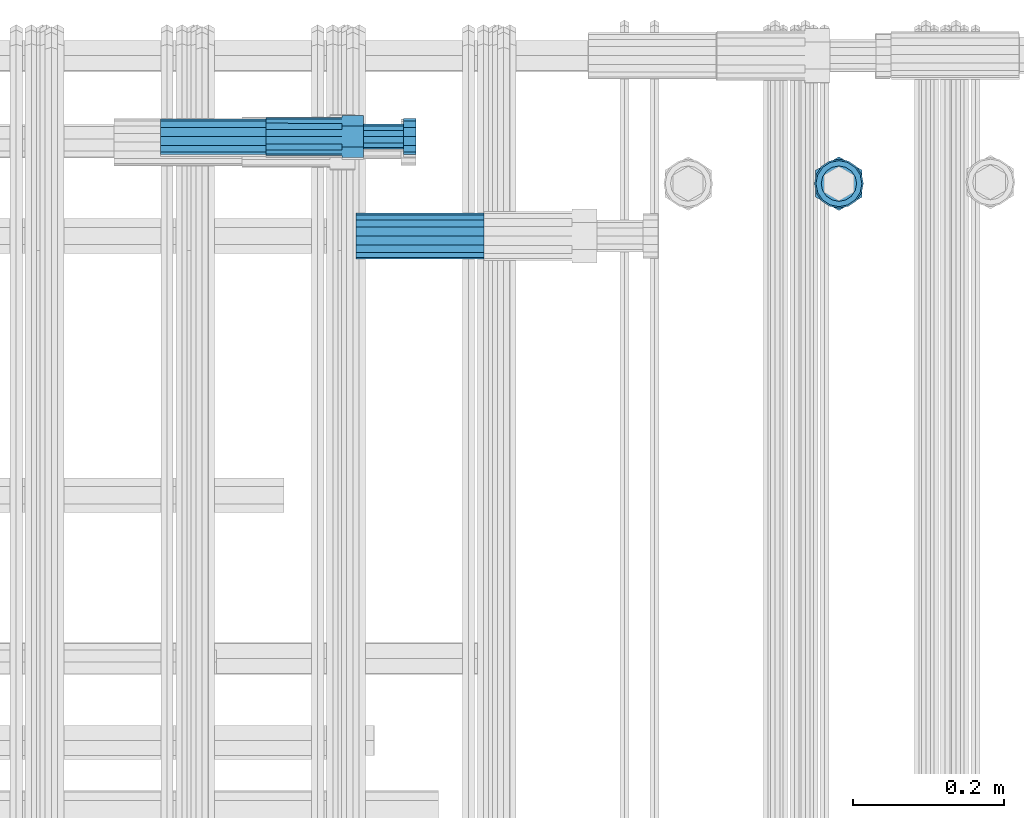
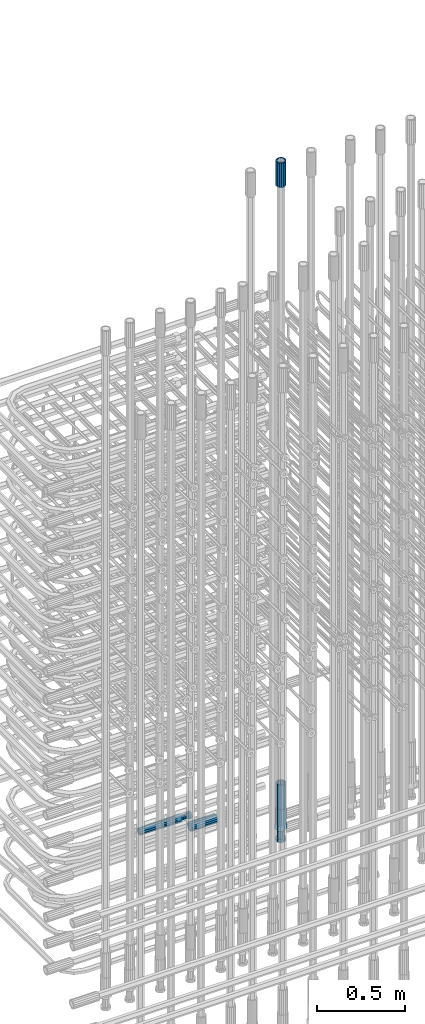
# One storey, part 43 of 177: 6 beams.
"""IFC2X3 building model written with IfcOpenShell, lengths in millimetres."""

from ifc_helpers import new_model, si_unit, frame, origin_with_axes, place, context, subcontext, project, spatial, faceted_brep, material, type_object, element, save


model = new_model("IFC2X3")

# Units and contexts
model_context_1 = context("Model", 3, precision=1e-05, world=origin_with_axes())
model_context_2 = context("Model", 3, precision=1e-05, world=origin_with_axes())
body_context = subcontext(model_context_2, "Body", "Model", "MODEL_VIEW")
ifc_project = project(units=[si_unit("LENGTHUNIT", "METRE", prefix="MILLI"), si_unit("AREAUNIT", "SQUARE_METRE"), si_unit("VOLUMEUNIT", "CUBIC_METRE"), si_unit("MASSUNIT", "GRAM", prefix="KILO"), si_unit("TIMEUNIT", "SECOND"), si_unit("PLANEANGLEUNIT", "RADIAN"), si_unit("SOLIDANGLEUNIT", "STERADIAN"), si_unit("THERMODYNAMICTEMPERATUREUNIT", "DEGREE_CELSIUS"), si_unit("LUMINOUSINTENSITYUNIT", "LUMEN")], contexts=[model_context_1])

# Site, building, storey
site_placement = place(None, origin_with_axes())
site = spatial("IfcSite", under=ifc_project, at=site_placement, CompositionType="ELEMENT")
building_placement = place(site_placement, origin_with_axes())
building = spatial("IfcBuilding", under=site, at=building_placement, Name="Undefined", CompositionType="ELEMENT")
storey_placement = place(building_placement, origin_with_axes())
storey = spatial("IfcBuildingStorey", under=building, at=storey_placement, Name="Undefined", CompositionType="ELEMENT", Elevation=0.0)

# Beams
ifc_material = material(Name="STEEL/S275")
beam_type_1 = type_object("IfcBeamType", PredefinedType="NOTDEFINED")
beam_1_placement = place(storey_placement, frame((2031781.00159327, 6206228.99448018, 19060.9668004296), z_axis=(-1.0, 0.0, 0.0), x_axis=(0.0, 0.0, -1.0)))
element("IfcBeam", 1, at=beam_1_placement, inside=storey, type_object=beam_type_1, material=ifc_material, Name="AG40N", context=body_context, shape_type="Brep", body=[
    faceted_brep([(0.0, -23.5000000001164, -9.31322574615479e-10), (0.0, -21.7111690140155, 8.99306066054851), (170.0, -21.7111690140155, 8.99306066054851), (170.0, -23.5, 0.0), (0.0, -16.6170093578839, 16.6170093575493), (170.0, -16.6170093578839, 16.6170093575493), (0.0, -8.99306066057943, 21.7111690137535), (170.0, -8.99306066057943, 21.7111690137535), (0.0, 1.16415321826935e-10, 23.5), (170.0, 0.0, 23.5), (0.0, 8.99306066057943, 21.7111690137535), (170.0, 8.99306066057943, 21.7111690137535), (0.0, 16.6170093578839, 16.6170093575493), (170.0, 16.6170093578839, 16.6170093575493), (0.0, 21.7111690140155, 8.99306066054851), (170.0, 21.7111690140155, 8.99306066054851), (0.0, 23.5000000001164, -9.31322574615479e-10), (170.0, 23.5, 0.0), (0.0, 21.7111690140155, -8.99306066054851), (170.0, 21.7111690140155, -8.99306066054851), (0.0, 16.6170093578839, -16.6170093575493), (170.0, 16.6170093578839, -16.6170093575493), (0.0, 8.99306066057943, -21.7111690137535), (170.0, 8.99306066057943, -21.7111690137535), (0.0, 1.16415321826935e-10, -23.5000000009313), (170.0, 0.0, -23.5), (0.0, -8.99306066057943, -21.7111690137535), (170.0, -8.99306066057943, -21.7111690137535), (0.0, -16.6170093578839, -16.6170093575493), (170.0, -16.6170093578839, -16.6170093575493), (0.0, -21.7111690140155, -8.99306066054851), (170.0, -21.7111690140155, -8.99306066054851), (0.0, -30.5, 0.0), (0.0, -28.1783257415937, -11.6718446873128), (170.0, -28.1783257415937, -11.6718446873128), (170.0, -30.5, 0.0), (0.0, -21.5667568261888, -21.5667568258941), (170.0, -21.5667568261888, -21.5667568258941), (0.0, -11.6718446871346, -28.1783257415518), (170.0, -11.6718446871346, -28.1783257415518), (0.0, 0.0, -30.5), (170.0, 0.0, -30.5), (0.0, 11.6718446871346, -28.1783257415518), (170.0, 11.6718446871346, -28.1783257415518), (0.0, 21.5667568261888, -21.5667568258941), (170.0, 21.5667568261888, -21.5667568258941), (0.0, 28.1783257415937, -11.6718446873128), (170.0, 28.1783257415937, -11.6718446873128), (0.0, 30.5, 0.0), (170.0, 30.5, 0.0), (0.0, 28.1783257415937, 11.6718446873128), (170.0, 28.1783257415937, 11.6718446873128), (0.0, 21.5667568261888, 21.5667568258941), (170.0, 21.5667568261888, 21.5667568258941), (0.0, 11.6718446871346, 28.1783257415518), (170.0, 11.6718446871346, 28.1783257415518), (0.0, 0.0, 30.5), (170.0, 0.0, 30.5), (0.0, -11.6718446871346, 28.1783257415518), (170.0, -11.6718446871346, 28.1783257415518), (0.0, -21.5667568261888, 21.5667568258941), (170.0, -21.5667568261888, 21.5667568258941), (0.0, -28.1783257415937, 11.6718446873128), (170.0, -28.1783257415937, 11.6718446873128)], [[[0, 1, 2, 3]], [[1, 4, 5, 2]], [[4, 6, 7, 5]], [[6, 8, 9, 7]], [[8, 10, 11, 9]], [[10, 12, 13, 11]], [[12, 14, 15, 13]], [[14, 16, 17, 15]], [[16, 18, 19, 17]], [[18, 20, 21, 19]], [[20, 22, 23, 21]], [[22, 24, 25, 23]], [[24, 26, 27, 25]], [[26, 28, 29, 27]], [[28, 30, 31, 29]], [[30, 0, 3, 31]], [[32, 33, 34, 35]], [[33, 36, 37, 34]], [[36, 38, 39, 37]], [[38, 40, 41, 39]], [[40, 42, 43, 41]], [[42, 44, 45, 43]], [[44, 46, 47, 45]], [[46, 48, 49, 47]], [[48, 50, 51, 49]], [[50, 52, 53, 51]], [[52, 54, 55, 53]], [[54, 56, 57, 55]], [[56, 58, 59, 57]], [[58, 60, 61, 59]], [[60, 62, 63, 61]], [[62, 32, 35, 63]], [[37, 39, 41, 43, 45, 47, 49, 51, 53, 55, 57, 59, 61, 63, 35, 34], [5, 7, 9, 11, 13, 15, 17, 19, 21, 23, 25, 27, 29, 31, 3, 2]], [[62, 60, 58, 56, 54, 52, 50, 48, 46, 44, 42, 40, 38, 36, 33, 32], [30, 28, 26, 24, 22, 20, 18, 16, 14, 12, 10, 8, 6, 4, 1, 0]]]),
])
beam_2_placement = place(storey_placement, frame((2031781.00159327, 6206228.99448019, 23229.9858194828), z_axis=(1.0, 0.0, 0.0), x_axis=(0.0, 0.0, 1.0)))
element("IfcBeam", 2, at=beam_2_placement, inside=storey, type_object=beam_type_1, material=ifc_material, Name="AG40N", context=body_context, shape_type="Brep", body=[
    faceted_brep([(0.0, -23.5000000001164, -9.31322574615479e-10), (0.0, -21.7111690140155, 8.99306066054851), (170.0, -21.7111690140155, 8.99306066054851), (170.0, -23.5, 0.0), (0.0, -16.6170093578839, 16.6170093575493), (170.0, -16.6170093578839, 16.6170093575493), (0.0, -8.99306066057943, 21.7111690137535), (170.0, -8.99306066057943, 21.7111690137535), (0.0, 1.16415321826935e-10, 23.5), (170.0, 0.0, 23.5), (0.0, 8.99306066057943, 21.7111690137535), (170.0, 8.99306066057943, 21.7111690137535), (0.0, 16.6170093578839, 16.6170093575493), (170.0, 16.6170093578839, 16.6170093575493), (0.0, 21.7111690140155, 8.99306066054851), (170.0, 21.7111690140155, 8.99306066054851), (0.0, 23.5000000001164, -9.31322574615479e-10), (170.0, 23.5, 0.0), (0.0, 21.7111690140155, -8.99306066054851), (170.0, 21.7111690140155, -8.99306066054851), (0.0, 16.6170093578839, -16.6170093575493), (170.0, 16.6170093578839, -16.6170093575493), (0.0, 8.99306066057943, -21.7111690137535), (170.0, 8.99306066057943, -21.7111690137535), (0.0, 1.16415321826935e-10, -23.5000000009313), (170.0, 0.0, -23.5), (0.0, -8.99306066057943, -21.7111690137535), (170.0, -8.99306066057943, -21.7111690137535), (0.0, -16.6170093578839, -16.6170093575493), (170.0, -16.6170093578839, -16.6170093575493), (0.0, -21.7111690140155, -8.99306066054851), (170.0, -21.7111690140155, -8.99306066054851), (0.0, -30.5, 0.0), (0.0, -28.1783257415937, -11.6718446873128), (170.0, -28.1783257415937, -11.6718446873128), (170.0, -30.5, 0.0), (0.0, -21.5667568261888, -21.5667568258941), (170.0, -21.5667568261888, -21.5667568258941), (0.0, -11.6718446871346, -28.1783257415518), (170.0, -11.6718446871346, -28.1783257415518), (0.0, 0.0, -30.5), (170.0, 0.0, -30.5), (0.0, 11.6718446871346, -28.1783257415518), (170.0, 11.6718446871346, -28.1783257415518), (0.0, 21.5667568261888, -21.5667568258941), (170.0, 21.5667568261888, -21.5667568258941), (0.0, 28.1783257415937, -11.6718446873128), (170.0, 28.1783257415937, -11.6718446873128), (0.0, 30.5, 0.0), (170.0, 30.5, 0.0), (0.0, 28.1783257415937, 11.6718446873128), (170.0, 28.1783257415937, 11.6718446873128), (0.0, 21.5667568261888, 21.5667568258941), (170.0, 21.5667568261888, 21.5667568258941), (0.0, 11.6718446871346, 28.1783257415518), (170.0, 11.6718446871346, 28.1783257415518), (0.0, 0.0, 30.5), (170.0, 0.0, 30.5), (0.0, -11.6718446871346, 28.1783257415518), (170.0, -11.6718446871346, 28.1783257415518), (0.0, -21.5667568261888, 21.5667568258941), (170.0, -21.5667568261888, 21.5667568258941), (0.0, -28.1783257415937, 11.6718446873128), (170.0, -28.1783257415937, 11.6718446873128)], [[[0, 1, 2, 3]], [[1, 4, 5, 2]], [[4, 6, 7, 5]], [[6, 8, 9, 7]], [[8, 10, 11, 9]], [[10, 12, 13, 11]], [[12, 14, 15, 13]], [[14, 16, 17, 15]], [[16, 18, 19, 17]], [[18, 20, 21, 19]], [[20, 22, 23, 21]], [[22, 24, 25, 23]], [[24, 26, 27, 25]], [[26, 28, 29, 27]], [[28, 30, 31, 29]], [[30, 0, 3, 31]], [[32, 33, 34, 35]], [[33, 36, 37, 34]], [[36, 38, 39, 37]], [[38, 40, 41, 39]], [[40, 42, 43, 41]], [[42, 44, 45, 43]], [[44, 46, 47, 45]], [[46, 48, 49, 47]], [[48, 50, 51, 49]], [[50, 52, 53, 51]], [[52, 54, 55, 53]], [[54, 56, 57, 55]], [[56, 58, 59, 57]], [[58, 60, 61, 59]], [[60, 62, 63, 61]], [[62, 32, 35, 63]], [[37, 39, 41, 43, 45, 47, 49, 51, 53, 55, 57, 59, 61, 63, 35, 34], [5, 7, 9, 11, 13, 15, 17, 19, 21, 23, 25, 27, 29, 31, 3, 2]], [[62, 60, 58, 56, 54, 52, 50, 48, 46, 44, 42, 40, 38, 36, 33, 32], [30, 28, 26, 24, 22, 20, 18, 16, 14, 12, 10, 8, 6, 4, 1, 0]]]),
])
beam_3_placement = place(storey_placement, frame((2031140.04841256, 6206159.48587195, 19018.4868004291), z_axis=(0.0, 0.0, -1.0), x_axis=(1.0, 0.0, 0.0)))
element("IfcBeam", 3, at=beam_3_placement, inside=storey, type_object=beam_type_1, material=ifc_material, Name="AG40N", context=body_context, shape_type="Brep", body=[
    faceted_brep([(0.0, -23.5000000001164, -9.31322574615479e-10), (0.0, -21.7111690140155, 8.99306066054851), (170.0, -21.7111690140155, 8.99306066054851), (170.0, -23.5, 0.0), (0.0, -16.6170093578839, 16.6170093575493), (170.0, -16.6170093578839, 16.6170093575493), (0.0, -8.99306066057943, 21.7111690137535), (170.0, -8.99306066057943, 21.7111690137535), (0.0, 1.16415321826935e-10, 23.5), (170.0, 0.0, 23.5), (0.0, 8.99306066057943, 21.7111690137535), (170.0, 8.99306066057943, 21.7111690137535), (0.0, 16.6170093578839, 16.6170093575493), (170.0, 16.6170093578839, 16.6170093575493), (0.0, 21.7111690140155, 8.99306066054851), (170.0, 21.7111690140155, 8.99306066054851), (0.0, 23.5000000001164, -9.31322574615479e-10), (170.0, 23.5, 0.0), (0.0, 21.7111690140155, -8.99306066054851), (170.0, 21.7111690140155, -8.99306066054851), (0.0, 16.6170093578839, -16.6170093575493), (170.0, 16.6170093578839, -16.6170093575493), (0.0, 8.99306066057943, -21.7111690137535), (170.0, 8.99306066057943, -21.7111690137535), (0.0, 1.16415321826935e-10, -23.5000000009313), (170.0, 0.0, -23.5), (0.0, -8.99306066057943, -21.7111690137535), (170.0, -8.99306066057943, -21.7111690137535), (0.0, -16.6170093578839, -16.6170093575493), (170.0, -16.6170093578839, -16.6170093575493), (0.0, -21.7111690140155, -8.99306066054851), (170.0, -21.7111690140155, -8.99306066054851), (0.0, -30.5, 0.0), (0.0, -28.1783257415937, -11.6718446873128), (170.0, -28.1783257415937, -11.6718446873128), (170.0, -30.5, 0.0), (0.0, -21.5667568261888, -21.5667568258941), (170.0, -21.5667568261888, -21.5667568258941), (0.0, -11.6718446871346, -28.1783257415518), (170.0, -11.6718446871346, -28.1783257415518), (0.0, 0.0, -30.5), (170.0, 0.0, -30.5), (0.0, 11.6718446871346, -28.1783257415518), (170.0, 11.6718446871346, -28.1783257415518), (0.0, 21.5667568261888, -21.5667568258941), (170.0, 21.5667568261888, -21.5667568258941), (0.0, 28.1783257415937, -11.6718446873128), (170.0, 28.1783257415937, -11.6718446873128), (0.0, 30.5, 0.0), (170.0, 30.5, 0.0), (0.0, 28.1783257415937, 11.6718446873128), (170.0, 28.1783257415937, 11.6718446873128), (0.0, 21.5667568261888, 21.5667568258941), (170.0, 21.5667568261888, 21.5667568258941), (0.0, 11.6718446871346, 28.1783257415518), (170.0, 11.6718446871346, 28.1783257415518), (0.0, 0.0, 30.5), (170.0, 0.0, 30.5), (0.0, -11.6718446871346, 28.1783257415518), (170.0, -11.6718446871346, 28.1783257415518), (0.0, -21.5667568261888, 21.5667568258941), (170.0, -21.5667568261888, 21.5667568258941), (0.0, -28.1783257415937, 11.6718446873128), (170.0, -28.1783257415937, 11.6718446873128)], [[[0, 1, 2, 3]], [[1, 4, 5, 2]], [[4, 6, 7, 5]], [[6, 8, 9, 7]], [[8, 10, 11, 9]], [[10, 12, 13, 11]], [[12, 14, 15, 13]], [[14, 16, 17, 15]], [[16, 18, 19, 17]], [[18, 20, 21, 19]], [[20, 22, 23, 21]], [[22, 24, 25, 23]], [[24, 26, 27, 25]], [[26, 28, 29, 27]], [[28, 30, 31, 29]], [[30, 0, 3, 31]], [[32, 33, 34, 35]], [[33, 36, 37, 34]], [[36, 38, 39, 37]], [[38, 40, 41, 39]], [[40, 42, 43, 41]], [[42, 44, 45, 43]], [[44, 46, 47, 45]], [[46, 48, 49, 47]], [[48, 50, 51, 49]], [[50, 52, 53, 51]], [[52, 54, 55, 53]], [[54, 56, 57, 55]], [[56, 58, 59, 57]], [[58, 60, 61, 59]], [[60, 62, 63, 61]], [[62, 32, 35, 63]], [[37, 39, 41, 43, 45, 47, 49, 51, 53, 55, 57, 59, 61, 63, 35, 34], [5, 7, 9, 11, 13, 15, 17, 19, 21, 23, 25, 27, 29, 31, 3, 2]], [[62, 60, 58, 56, 54, 52, 50, 48, 46, 44, 42, 40, 38, 36, 33, 32], [30, 28, 26, 24, 22, 20, 18, 16, 14, 12, 10, 8, 6, 4, 1, 0]]]),
])
beam_type_2 = type_object("IfcBeamType", Name="ROD65", PredefinedType="NOTDEFINED")
beam_4_placement = place(storey_placement, frame((2031781.00159327, 6206228.99448018, 18890.9668004296), z_axis=(-1.0, 0.0, 0.0), x_axis=(0.0, 0.0, -1.0)))
element("IfcBeam", 4, at=beam_4_placement, inside=storey, type_object=beam_type_2, material=ifc_material, Name="AGB40", ObjectType="ROD65", context=body_context, shape_type="Brep", body=[
    faceted_brep([(117.0, 8.17543110251427, 30.873805644922), (117.0, 17.8250000001863, 30.873805644922), (117.0, 22.0056958701462, 23.6326279877685), (117.0, 12.4372115517035, 30.0260848065373), (117.0, -17.8250000001863, 30.873805644922), (150.200000000186, -17.8250000001863, 30.873805644922), (150.200000000186, 17.8250000001863, 30.873805644922), (117.0, -8.17543110251427, 30.873805644922), (117.0, -12.4372115517035, 30.0260848065373), (117.0, -22.0056958701462, 23.6326279877685), (117.0, -35.6500000003725, 0.0), (150.200000000186, -35.6500000003725, 0.0), (117.0, -30.8443150008097, 8.32369058486074), (117.0, -32.5, 0.0), (117.0, -30.8443150008097, -8.32369058462791), (117.0, -17.8250000001863, -30.873805644922), (150.200000000186, -17.8250000001863, -30.873805644922), (117.0, -22.0056958701462, -23.6326279877685), (117.0, -12.4372115517035, -30.0260848065373), (117.0, -8.17543110251427, -30.873805644922), (117.0, 17.8250000001863, -30.873805644922), (150.200000000186, 17.8250000001863, -30.873805644922), (117.0, 8.17543110251427, -30.873805644922), (117.0, 22.0056958701462, -23.6326279877685), (117.0, 12.4372115517035, -30.0260848065373), (117.0, 35.6500000003725, 0.0), (150.200000000186, 35.6500000003725, 0.0), (117.0, 30.8443150008097, -8.32369058486074), (117.0, 30.8443150008097, 8.32369058462791), (117.0, 32.5, 0.0), (0.0, -22.9809703892097, 22.9809703885621), (0.0, -30.0260848058388, 12.4372115518636), (117.0, -30.0260848067701, 12.4372115519363), (117.0, -22.9809703882784, 22.9809703885112), (-2.3283064365387e-10, 22.9809703892097, -22.9809703885639), (-4.65661287307739e-10, 30.0260848077014, -12.4372115518672), (117.0, 30.0260848067701, -12.4372115519363), (117.0, 22.9809703882784, -22.9809703885112), (-2.3283064365387e-10, -30.0260848067701, -12.4372115518672), (-2.3283064365387e-10, -22.9809703892097, -22.9809703885621), (117.0, -22.9809703882784, -22.9809703885112), (117.0, -30.0260848067701, -12.4372115519363), (-2.3283064365387e-10, -12.4372115507722, 30.0260848066137), (-2.3283064365387e-10, 9.31322574615479e-10, 32.4999999999982), (-2.3283064365387e-10, 12.4372115526348, 30.0260848066137), (0.0, 22.9809703892097, 22.9809703885621), (-2.3283064365387e-10, 30.0260848077014, 12.4372115518636), (-2.3283064365387e-10, 32.5, 0.0), (-2.3283064365387e-10, 12.4372115526348, -30.0260848066173), (-2.3283064365387e-10, 9.31322574615479e-10, -32.5), (-2.3283064365387e-10, -12.4372115517035, -30.0260848066173), (-4.65661287307739e-10, -32.4999999990687, -1.81898940354586e-12), (117.0, 22.9809703882784, 22.9809703885112), (117.0, 30.0260848067701, 12.4372115519363), (117.0, 0.0, -32.5), (117.0, 0.0, 32.5), (150.200000000186, 10.5, -18.1865334794857), (150.200000000186, 0.0, -21.0), (150.200000000186, -10.5, -18.1865334794857), (150.200000000186, -18.18653347902, -10.5), (150.200000000186, -21.0, 0.0), (150.200000000186, -18.18653347902, 10.5), (150.200000000186, -10.5, 18.1865334794857), (150.200000000186, 0.0, 21.0), (150.200000000186, 10.5, 18.1865334794857), (150.200000000186, 18.18653347902, 10.5), (150.200000000186, 21.0, 0.0), (150.200000000186, 18.18653347902, -10.5), (210.980000000447, -10.5, -18.1865334794857), (210.980000000447, 0.0, -21.0), (210.980000000447, -18.18653347902, -10.5), (210.980000000447, -21.0, 0.0), (210.980000000447, -18.18653347902, 10.5), (210.980000000447, -10.5, 18.1865334794857), (210.980000000447, 0.0, 21.0), (210.980000000447, 10.5, 18.1865334794857), (210.980000000447, 18.18653347902, 10.5), (210.980000000447, 21.0, 0.0), (210.980000000447, 18.18653347902, -10.5), (210.980000000447, 10.5, -18.1865334794857), (211.001368442696, -27.7269937992096, -11.491116326768), (211.003082550167, -21.2238094303757, -21.223815418547), (231.002518367059, -21.2131944671273, -21.2132004550658), (231.000804259587, -27.7163788359612, -11.4805013632867), (211.001368440451, -11.4911085031927, -27.7269970395137), (231.000804257343, -11.4804935399443, -27.7163820760325), (210.996487071217, -0.0106065049767494, -30.0106107392348), (230.995922888109, 8.45827162265778e-06, -29.9999957757536), (210.989181586672, 11.46989420522, -27.7269970329944), (230.988617403564, 11.4805091684684, -27.7163820695132), (210.980564180623, 21.2025914648548, -21.2238154064398), (230.979999997515, 21.2132064281031, -21.2132004429586), (210.971946775022, 27.7057703435421, -11.4911163107026), (230.971382591913, 27.7163853067905, -11.4805013472214), (210.96464129175, 29.9893808094785, -0.0106149562634528), (230.964077108642, 29.9999957727268, 7.21774995326996e-09), (210.959759924415, 27.7057638689876, 11.4698863970116), (230.959195741307, 27.7163788322359, 11.4805013604928), (210.958045816944, 21.2025795001537, 21.2025854887906), (230.957481633835, 21.213194463402, 21.2132004522718), (210.95975992666, 11.4698785729706, 27.7057671097573), (230.959195743551, 11.480493536219, 27.7163820732385), (210.964641295894, -0.010623425245285, 29.9893808094785), (230.964077112785, -8.46199691295624e-06, 29.9999957729597), (210.971946780439, -11.4911241354421, 27.705767103238), (230.97138259733, -11.4805091721937, 27.7163820667192), (210.980564186488, -21.2238213950768, 21.2025854766835), (230.980000003379, -21.2132064318284, 21.2132004401647), (210.989181592089, -27.7270002737641, 11.4698863809463), (230.988617408981, -27.7163853105158, 11.4805013444275), (210.996487075361, -30.0106107397005, -0.0106149734929204), (230.995922892253, -29.9999957764521, -1.00117176771164e-08)], [[[0, 1, 2, 3]], [[4, 5, 6, 1, 0, 7]], [[4, 7, 8, 9]], [[10, 11, 5, 4, 9, 12]], [[10, 12, 13, 14]], [[15, 16, 11, 10, 14, 17]], [[15, 17, 18, 19]], [[20, 21, 16, 15, 19, 22]], [[23, 20, 22, 24]], [[25, 26, 21, 20, 23, 27]], [[28, 25, 27, 29]], [[30, 31, 32, 33]], [[34, 35, 36, 37]], [[38, 39, 40, 41]], [[31, 30, 42, 43, 44, 45, 46, 47, 35, 34, 48, 49, 50, 39, 38, 51]], [[46, 45, 52, 53]], [[29, 47, 46, 53, 28]], [[27, 36, 35, 47, 29]], [[23, 37, 36, 27]], [[24, 48, 34, 37, 23]], [[22, 54, 49, 48, 24]], [[19, 54, 22]], [[18, 50, 49, 54, 19]], [[17, 40, 39, 50, 18]], [[14, 41, 40, 17]], [[13, 51, 38, 41, 14]], [[12, 32, 31, 51, 13]], [[9, 33, 32, 12]], [[8, 42, 30, 33, 9]], [[7, 55, 43, 42, 8]], [[0, 55, 7]], [[3, 44, 43, 55, 0]], [[2, 52, 45, 44, 3]], [[28, 53, 52, 2]], [[1, 6, 26, 25, 28, 2]], [[5, 11, 16, 21, 26, 6], [56, 57, 58, 59, 60, 61, 62, 63, 64, 65, 66, 67]], [[68, 58, 57, 69]], [[70, 59, 58, 68]], [[71, 60, 59, 70]], [[72, 61, 60, 71]], [[73, 62, 61, 72]], [[74, 63, 62, 73]], [[75, 64, 63, 74]], [[76, 65, 64, 75]], [[77, 66, 65, 76]], [[78, 67, 66, 77]], [[79, 56, 67, 78]], [[69, 57, 56, 79]], [[80, 81, 82, 83]], [[81, 84, 85, 82]], [[84, 86, 87, 85]], [[86, 88, 89, 87]], [[88, 90, 91, 89]], [[90, 92, 93, 91]], [[92, 94, 95, 93]], [[94, 96, 97, 95]], [[96, 98, 99, 97]], [[98, 100, 101, 99]], [[100, 102, 103, 101]], [[102, 104, 105, 103]], [[104, 106, 107, 105]], [[106, 108, 109, 107]], [[108, 110, 111, 109]], [[82, 85, 87, 89, 91, 93, 95, 97, 99, 101, 103, 105, 107, 109, 111, 83]], [[110, 80, 83, 111]], [[108, 106, 104, 102, 100, 98, 96, 94, 92, 90, 88, 86, 84, 81, 80, 110], [78, 77, 76, 75, 74, 73, 72, 71, 70, 68, 69, 79]]]),
])
beam_type_3 = type_object("IfcBeamType", PredefinedType="NOTDEFINED")
beam_5_placement = place(storey_placement, frame((2030880.99847313, 6206291.48588035, 18994.4868004347), z_axis=(0.0, 0.0, -1.0), x_axis=(1.0, 0.0, 0.0)))
element("IfcBeam", 5, at=beam_5_placement, inside=storey, type_object=beam_type_3, material=ifc_material, Name="AG32N", context=body_context, shape_type="Brep", body=[
    faceted_brep([(0.0, -18.4999999998836, -9.31322574615479e-10), (7.0839612702856e-11, -16.0214699700121, 9.25), (140.0, -16.0214699698845, 9.24999999906868), (140.0, -18.4999999998836, -9.31322574615479e-10), (0.0, -9.24999999988358, 16.0214699683711), (140.0, -9.24999999988358, 16.0214699683711), (9.69157554209232e-11, 0.0, 18.5), (140.0, -1.16415321826935e-10, 18.4999999981374), (0.0, 9.24999999988358, 16.0214699683711), (140.0, 9.24999999988358, 16.0214699683711), (2.60761427180671e-11, 16.0214699700121, 9.24999999999999), (140.0, 16.0214699698845, 9.24999999906868), (0.0, 18.5000000001164, -9.31322574615479e-10), (140.0, 18.5000000001164, -9.31322574615479e-10), (-7.0839612702856e-11, 16.0214699700121, -9.25000000000001), (140.0, 16.0214699701173, -9.25000000093132), (0.0, 9.25000000011642, -16.0214699711651), (140.0, 9.25000000011642, -16.0214699711651), (-9.69157554209232e-11, -7.18869408444789e-15, -18.5), (140.0, -1.16415321826935e-10, -18.5000000009313), (0.0, -9.25000000011642, -16.0214699702337), (140.0, -9.25000000011642, -16.0214699702337), (-2.60761427180672e-11, -16.0214699700121, -9.25), (140.0, -16.0214699701173, -9.25000000093132), (0.0, -23.5000000001164, -9.31322574615479e-10), (0.0, -20.3515969890868, -11.75), (140.0, -20.3515969890868, -11.75), (140.0, -23.5000000001164, -9.31322574615479e-10), (0.0, -11.7500000001164, -20.3515969896689), (140.0, -11.7500000001164, -20.3515969896689), (0.0, 1.16415321826935e-10, -23.5000000009313), (140.0, 1.16415321826935e-10, -23.5000000009313), (0.0, 11.7500000001164, -20.3515969896689), (140.0, 11.7500000001164, -20.3515969896689), (0.0, 20.3515969890868, -11.7500000009313), (140.0, 20.3515969890868, -11.7500000009313), (0.0, 23.5000000001164, -9.31322574615479e-10), (140.0, 23.5000000001164, -9.31322574615479e-10), (0.0, 20.351596988854, 11.7499999990687), (140.0, 20.351596988854, 11.7499999990687), (0.0, 11.7499999998836, 20.3515969878063), (140.0, 11.7499999998836, 20.3515969878063), (0.0, 1.16415321826935e-10, 23.5), (140.0, 1.16415321826935e-10, 23.5), (0.0, -11.7499999998836, 20.3515969887376), (140.0, -11.7499999998836, 20.3515969887376), (0.0, -20.3515969893197, 11.7499999981374), (140.0, -20.3515969893197, 11.7499999981374)], [[[0, 1, 2, 3]], [[1, 4, 5, 2]], [[4, 6, 7, 5]], [[6, 8, 9, 7]], [[8, 10, 11, 9]], [[10, 12, 13, 11]], [[12, 14, 15, 13]], [[14, 16, 17, 15]], [[16, 18, 19, 17]], [[18, 20, 21, 19]], [[20, 22, 23, 21]], [[22, 0, 3, 23]], [[24, 25, 26, 27]], [[25, 28, 29, 26]], [[28, 30, 31, 29]], [[30, 32, 33, 31]], [[32, 34, 35, 33]], [[34, 36, 37, 35]], [[36, 38, 39, 37]], [[38, 40, 41, 39]], [[40, 42, 43, 41]], [[42, 44, 45, 43]], [[44, 46, 47, 45]], [[46, 24, 27, 47]], [[29, 31, 33, 35, 37, 39, 41, 43, 45, 47, 27, 26], [5, 7, 9, 11, 13, 15, 17, 19, 21, 23, 3, 2]], [[46, 44, 42, 40, 38, 36, 34, 32, 30, 28, 25, 24], [22, 20, 18, 16, 14, 12, 10, 8, 6, 4, 1, 0]]]),
])
beam_type_4 = type_object("IfcBeamType", Name="ROD50", PredefinedType="NOTDEFINED")
beam_6_placement = place(storey_placement, frame((2031020.99847313, 6206291.48588035, 18994.4868004347), z_axis=(0.0, 0.0, -1.0), x_axis=(1.0, 0.0, 0.0)))
element("IfcBeam", 6, at=beam_6_placement, inside=storey, type_object=beam_type_4, material=ifc_material, Name="AGB32", ObjectType="ROD50", context=body_context, shape_type="Brep", body=[
    faceted_brep([(129.100000000559, -13.8425000002608, 23.9759132992476), (129.100000000559, -27.6850000005215, -4.65661287307739e-09), (129.100000000559, -13.8424999993294, -23.9759133085608), (129.100000000559, 13.8425000002608, -23.975913308328), (129.100000000559, 27.6849999995902, -4.42378222942352e-09), (129.100000000559, 13.8424999993294, 23.9759132992476), (101.0, -13.8424999993294, -23.9759133085608), (101.0, -27.6850000005215, -4.65661287307739e-09), (101.0, -23.5887256413698, -7.09495531534776), (101.0, -17.528511938639, -17.5915533546358), (101.0, -9.56708580814302, -23.0969883131329), (101.0, -5.14843146782368, -23.975913308328), (101.0, 13.8425000002608, -23.975913308328), (101.0, 5.14843147061765, -23.975913308328), (101.0, 9.56708581000566, -23.0969883129001), (101.0, 17.5285119377077, -17.5915533537045), (101.0, 27.6849999995902, -4.42378222942352e-09), (101.0, 23.5887256432325, -7.09495531162247), (101.0, 25.0000000009313, -2.3283064365387e-10), (101.0, 23.5887256460264, 7.09495529648848), (101.0, 13.8424999993294, 23.9759132992476), (101.0, 17.5285119339824, 17.5915533511434), (101.0, 5.14843151345849, 23.9759132992476), (101.0, 9.56708581000566, 23.0969883126672), (101.0, -13.8425000002608, 23.9759132992476), (101.0, -5.14843151252717, 23.9759132990148), (101.0, -17.5285119339824, 17.5915533518419), (101.0, -9.56708580814302, 23.0969883126672), (101.0, -23.5887256441638, 7.09495530254208), (101.0, -24.9999999990687, -2.3283064365387e-10), (101.0, -23.0969883119687, 9.56708580884151), (0.0, -23.0969883129001, 9.56708580912709), (0.0, -25.0, 0.0), (0.0, -17.6776695298031, 17.677669529663), (0.0, -9.56708580907434, 23.0969883127818), (101.0, 9.31322574615479e-10, 24.9999999997672), (0.0, 0.0, 25.0), (0.0, 9.56708580907434, 23.0969883127818), (0.0, 17.6776695298031, 17.677669529663), (0.0, 23.0969883129001, 9.56708580912709), (101.0, 23.0969883138314, 9.56708580884151), (0.0, 25.0, 0.0), (101.0, 23.0969883138314, -9.56708580930717), (0.0, 23.0969883129001, -9.56708580912709), (0.0, 17.6776695298031, -17.677669529663), (0.0, 9.56708580907434, -23.0969883127818), (101.0, 0.0, -25.0), (0.0, 0.0, -25.0), (0.0, -9.56708580907434, -23.0969883127818), (0.0, -17.6776695298031, -17.677669529663), (0.0, -23.0969883129001, -9.56708580912709), (101.0, -23.0969883119687, -9.56708580930717), (129.5, -14.2894191620871, 8.24999999511056), (129.5, -8.25, 14.2894191578962), (129.5, 0.0, 16.4999999953434), (129.5, 8.25, 14.2894191576634), (129.5, 14.2894191620871, 8.24999999557622), (129.5, 16.5, -4.65661287307739e-09), (129.5, 14.2894191620871, -8.25000000465661), (129.5, 8.25, -14.2894191672094), (129.5, 0.0, -16.5000000046566), (129.5, -8.25000000093132, -14.2894191669766), (129.5, -14.2894191630185, -8.25000000465661), (129.5, -16.5, -4.65661287307739e-09), (182.500000000466, -14.2894191620871, 8.24999999511056), (182.500000000466, -16.5, -4.65661287307739e-09), (182.500000000466, -8.25, 14.2894191578962), (182.500000000466, 0.0, 16.4999999953434), (182.500000000466, 8.25, 14.2894191576634), (182.500000000466, 14.2894191620871, 8.24999999557622), (182.500000000466, 16.5, -4.65661287307739e-09), (182.500000000466, 14.2894191620871, -8.25000000465661), (182.500000000466, 8.25, -14.2894191672094), (182.500000000466, 0.0, -16.5000000046566), (182.500000000466, -8.25000000093132, -14.2894191669766), (182.500000000466, -14.2894191630185, -8.25000000465661), (182.5, -20.7846096921712, -12.0000000044238), (182.5, -12.0, -20.7846096954308), (199.0, -12.0, -20.7846096954308), (199.0, -20.7846096921712, -12.0000000044238), (182.5, -9.31322574615479e-10, -24.0000000044238), (199.0, -9.31322574615479e-10, -24.0000000044238), (182.5, 12.0, -20.7846096956637), (199.0, 12.0, -20.7846096956637), (182.5, 20.7846096912399, -12.0000000046566), (199.0, 20.7846096912399, -12.0000000046566), (182.5, 24.0, -4.65661287307739e-09), (199.0, 24.0, -4.65661287307739e-09), (182.5, 20.7846096912399, 11.9999999953434), (199.0, 20.7846096912399, 11.9999999953434), (182.5, 12.0, 20.7846096863504), (199.0, 12.0, 20.7846096863504), (182.5, -9.31322574615479e-10, 23.9999999953434), (199.0, -9.31322574615479e-10, 23.9999999953434), (182.5, -12.0000000009313, 20.7846096861176), (199.0, -12.0000000009313, 20.7846096861176), (182.5, -20.7846096912399, 11.9999999955762), (199.0, -20.7846096912399, 11.9999999955762), (182.5, -24.0, -4.65661287307739e-09), (199.0, -24.0, -4.65661287307739e-09)], [[[0, 1, 2, 3, 4, 5]], [[6, 2, 1, 7, 8, 9]], [[6, 9, 10, 11]], [[12, 3, 2, 6, 11, 13]], [[12, 13, 14, 15]], [[16, 4, 3, 12, 15, 17]], [[16, 17, 18, 19]], [[20, 5, 4, 16, 19, 21]], [[22, 20, 21, 23]], [[24, 0, 5, 20, 22, 25]], [[26, 24, 25, 27]], [[7, 1, 0, 24, 26, 28]], [[7, 28, 29, 8]], [[28, 30, 31, 32, 29]], [[26, 30, 28]], [[33, 31, 30, 26]], [[27, 34, 33, 26]], [[25, 35, 36, 34, 27]], [[22, 35, 25]], [[23, 37, 36, 35, 22]], [[21, 38, 37, 23]], [[39, 38, 21, 40]], [[19, 40, 21]], [[18, 41, 39, 40, 19]], [[17, 42, 43, 41, 18]], [[15, 42, 17]], [[44, 43, 42, 15]], [[14, 45, 44, 15]], [[13, 46, 47, 45, 14]], [[11, 46, 13]], [[10, 48, 47, 46, 11]], [[9, 49, 48, 10]], [[50, 49, 9, 51]], [[8, 51, 9]], [[29, 32, 50, 51, 8]], [[31, 33, 34, 36, 37, 38, 39, 41, 43, 44, 45, 47, 48, 49, 50, 32]], [[52, 53, 54, 55, 56, 57, 58, 59, 60, 61, 62, 63]], [[64, 52, 63, 65]], [[66, 53, 52, 64]], [[67, 54, 53, 66]], [[68, 55, 54, 67]], [[69, 56, 55, 68]], [[70, 57, 56, 69]], [[71, 58, 57, 70]], [[72, 59, 58, 71]], [[73, 60, 59, 72]], [[74, 61, 60, 73]], [[75, 62, 61, 74]], [[65, 63, 62, 75]], [[76, 77, 78, 79]], [[77, 80, 81, 78]], [[80, 82, 83, 81]], [[82, 84, 85, 83]], [[84, 86, 87, 85]], [[86, 88, 89, 87]], [[88, 90, 91, 89]], [[90, 92, 93, 91]], [[92, 94, 95, 93]], [[94, 96, 97, 95]], [[96, 98, 99, 97]], [[78, 81, 83, 85, 87, 89, 91, 93, 95, 97, 99, 79]], [[98, 76, 79, 99]], [[96, 94, 92, 90, 88, 86, 84, 82, 80, 77, 76, 98], [68, 67, 66, 64, 65, 75, 74, 73, 72, 71, 70, 69]]]),
])

save(model, "model.ifc")
